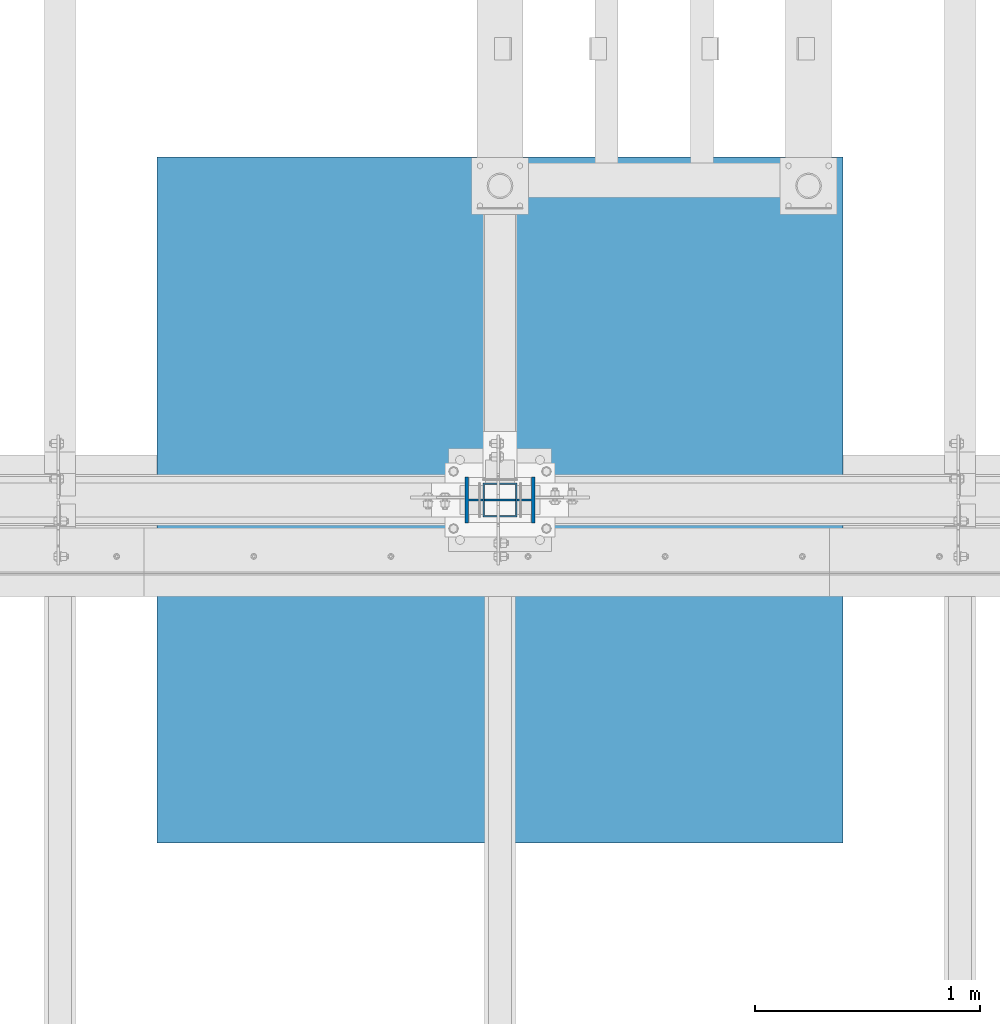
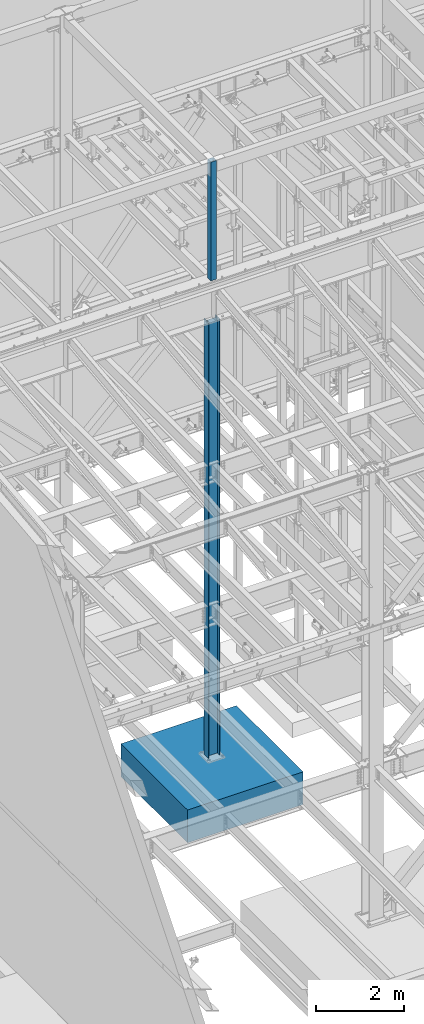
# One storey, part 368 of 1179: 3 columns, 3 elements without a shape of their own.
"""IFC2X3 building model written with IfcOpenShell, lengths in millimetres."""

from ifc_helpers import new_model, si_unit, frame, origin_with_axes, place, context, subcontext, project, spatial, faceted_brep, material, type_object, element, aggregate, save


model = new_model("IFC2X3")

# Units and contexts
model_context = context("Model", 3, precision=1e-05, world=origin_with_axes())
body_context = subcontext(model_context, "Body", "Model", "MODEL_VIEW")
ifc_project = project(units=[si_unit("LENGTHUNIT", "METRE", prefix="MILLI"), si_unit("AREAUNIT", "SQUARE_METRE"), si_unit("VOLUMEUNIT", "CUBIC_METRE"), si_unit("MASSUNIT", "GRAM", prefix="KILO"), si_unit("TIMEUNIT", "SECOND"), si_unit("PLANEANGLEUNIT", "RADIAN"), si_unit("SOLIDANGLEUNIT", "STERADIAN"), si_unit("THERMODYNAMICTEMPERATUREUNIT", "DEGREE_CELSIUS"), si_unit("LUMINOUSINTENSITYUNIT", "LUMEN")], contexts=[model_context])

# Site, building, storey
site_placement = place(None, origin_with_axes())
site = spatial("IfcSite", under=ifc_project, at=site_placement, CompositionType="ELEMENT")
building_placement = place(site_placement, origin_with_axes())
building = spatial("IfcBuilding", under=site, at=building_placement, Name="Undefined", CompositionType="ELEMENT")
storey_placement = place(building_placement, origin_with_axes())
storey = spatial("IfcBuildingStorey", under=building, at=storey_placement, Name="Undefined", CompositionType="ELEMENT", Elevation=0.0)

# Assembly, column
assembly_1_placement = place(storey_placement, origin_with_axes())
assembly_1 = element("IfcElementAssembly", 1, at=assembly_1_placement, inside=storey, Name="COLUMN", AssemblyPlace="NOTDEFINED", PredefinedType="RIGID_FRAME")
ifc_material_1 = material()
column_type_1 = type_object("IfcColumnType", Name="HSS6X6X1/4", PredefinedType="NOTDEFINED")
column_1_placement = place(assembly_1_placement, frame((8280.4, 34391.6, 13119.1), z_axis=(0.0, 1.0, 0.0), x_axis=(0.0, 0.0, 1.0)))
column_1 = element("IfcColumn", 2, at=column_1_placement, type_object=column_type_1, material=ifc_material_1, Name="COLUMN", ObjectType="HSS6X6X1/4", context=body_context, shape_type="Brep", body=[
    faceted_brep([(0.0, 69.8499999999985, -69.8499999999985), (0.0, -69.8499999999985, -69.8499999999985), (3308.35, -69.8499999999985, -69.8499999999985), (3308.35, 69.8499999999985, -69.8499999999985), (0.0, -69.8499999983651, 69.849999997823), (3308.35, -69.8499999999985, 69.8499999999985), (0.0, 69.8499999983651, 69.849999997823), (3308.35, 69.8499999999985, 69.8499999999985), (6.54836185276508e-11, 76.2, -76.1999999999998), (6.54836185276508e-11, 76.2, 76.1999999999998), (3308.35, 76.2000000000007, 76.1999999999971), (3308.35, 76.2000000000007, -76.1999999999971), (-6.54836185276508e-11, -76.2, 76.1999999999998), (3308.35, -76.2000000000007, 76.1999999999971), (-6.54836185276508e-11, -76.2, -76.1999999999998), (3308.35, -76.2000000000007, -76.1999999999971)], [[[0, 1, 2, 3]], [[1, 4, 5, 2]], [[4, 6, 7, 5]], [[6, 0, 3, 7]], [[8, 9, 10, 11]], [[9, 12, 13, 10]], [[12, 14, 15, 13]], [[14, 8, 11, 15]], [[13, 15, 11, 10], [5, 7, 3, 2]], [[14, 12, 9, 8], [6, 4, 1, 0]]]),
])
aggregate(assembly_1, [column_1])

assembly_2_placement = place(storey_placement, origin_with_axes())
assembly_2 = element("IfcElementAssembly", 3, at=assembly_2_placement, inside=storey, Name="FOOTING", AssemblyPlace="NOTDEFINED", PredefinedType="REINFORCEMENT_UNIT")
ifc_material_2 = material(Name="CONCRETE/3000")
column_type_2 = type_object("IfcColumnType", PredefinedType="NOTDEFINED")
column_2_placement = place(assembly_2_placement, frame((8280.4, 34391.6, -1168.4), z_axis=(-1.0, 0.0, 0.0), x_axis=(0.0, 0.0, 1.0)))
column_2 = element("IfcColumn", 4, at=column_2_placement, type_object=column_type_2, material=ifc_material_2, Name="FOOTING", context=body_context, shape_type="Brep", body=[
    faceted_brep([(0.0, 1524.0, -1524.0), (0.0, 1524.0, 1524.0), (914.4, 1524.0, 1524.0), (914.4, 1524.0, -1524.0), (0.0, -1524.0, 1524.0), (914.4, -1524.0, 1524.0), (0.0, -1524.0, -1524.0), (914.4, -1524.0, -1524.0)], [[[0, 1, 2, 3]], [[1, 4, 5, 2]], [[4, 6, 7, 5]], [[6, 0, 3, 7]], [[5, 7, 3, 2]], [[6, 4, 1, 0]]]),
])
aggregate(assembly_2, [column_2])

assembly_3_placement = place(storey_placement, origin_with_axes())
assembly_3 = element("IfcElementAssembly", 5, at=assembly_3_placement, inside=storey, Name="COLUMN", AssemblyPlace="NOTDEFINED", PredefinedType="RIGID_FRAME")
ifc_material_3 = material(Name="STEEL/A992")
column_type_3 = type_object("IfcColumnType", Name="W12X50", PredefinedType="NOTDEFINED")
column_3_placement = place(assembly_3_placement, frame((8280.4, 34391.6, -355.6), z_axis=(-1.0, 0.0, 0.0), x_axis=(0.0, 0.0, 1.0)))
column_3 = element("IfcColumn", 6, at=column_3_placement, type_object=column_type_3, material=ifc_material_3, Name="COLUMN", ObjectType="W12X50", context=body_context, shape_type="Brep", body=[
    faceted_brep([(190.5, 103.1875, -155.575000000001), (190.5, 103.1875, -139.700000000001), (12357.1, 103.1875, -139.700000000001), (12357.1, 103.1875, -155.575000000001), (190.5, 4.76249999999709, -139.700000000001), (12357.1, 4.76249999999709, -139.700000000001), (190.5, 4.76249999999709, 139.700000000001), (12357.1, 4.76249999999709, 139.700000000001), (190.5, 103.1875, 139.700000000001), (12357.1, 103.1875, 139.700000000001), (190.5, 103.1875, 155.575000000001), (12357.1, 103.1875, 155.575000000001), (190.5, -103.1875, 155.575000000001), (12357.1, -103.1875, 155.575000000001), (190.5, -103.1875, 139.700000000001), (12357.1, -103.1875, 139.700000000001), (190.5, -4.76249999999709, 139.700000000001), (12357.1, -4.76249999999709, 139.700000000001), (190.5, -4.76249999999709, -139.700000000001), (12357.1, -4.76249999999709, -139.700000000001), (190.5, -103.1875, -139.700000000001), (12357.1, -103.1875, -139.700000000001), (190.5, -103.1875, -155.575000000001), (12357.1, -103.1875, -155.575000000001)], [[[0, 1, 2, 3]], [[1, 4, 5, 2]], [[4, 6, 7, 5]], [[6, 8, 9, 7]], [[8, 10, 11, 9]], [[10, 12, 13, 11]], [[12, 14, 15, 13]], [[14, 16, 17, 15]], [[16, 18, 19, 17]], [[18, 20, 21, 19]], [[20, 22, 23, 21]], [[22, 0, 3, 23]], [[5, 7, 9, 11, 13, 15, 17, 19, 21, 23, 3, 2]], [[22, 20, 18, 16, 14, 12, 10, 8, 6, 4, 1, 0]]]),
])
aggregate(assembly_3, [column_3])

save(model, "model.ifc")
